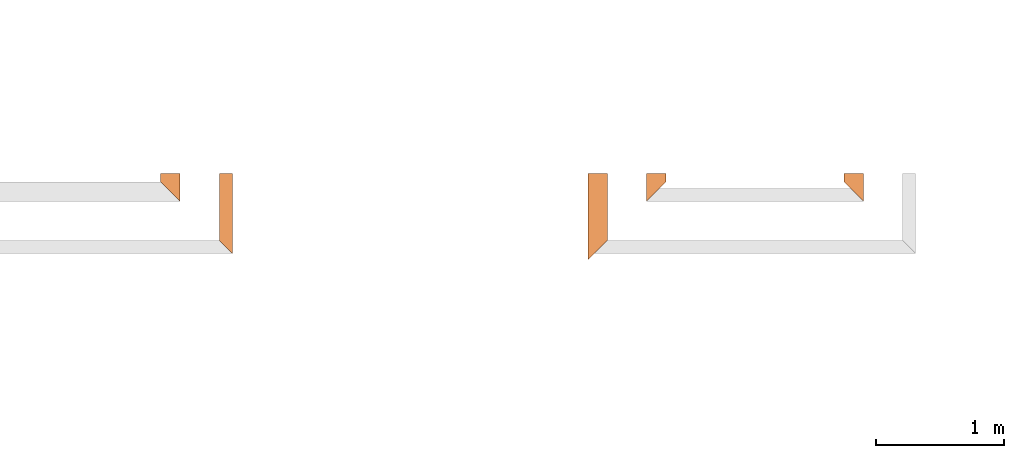
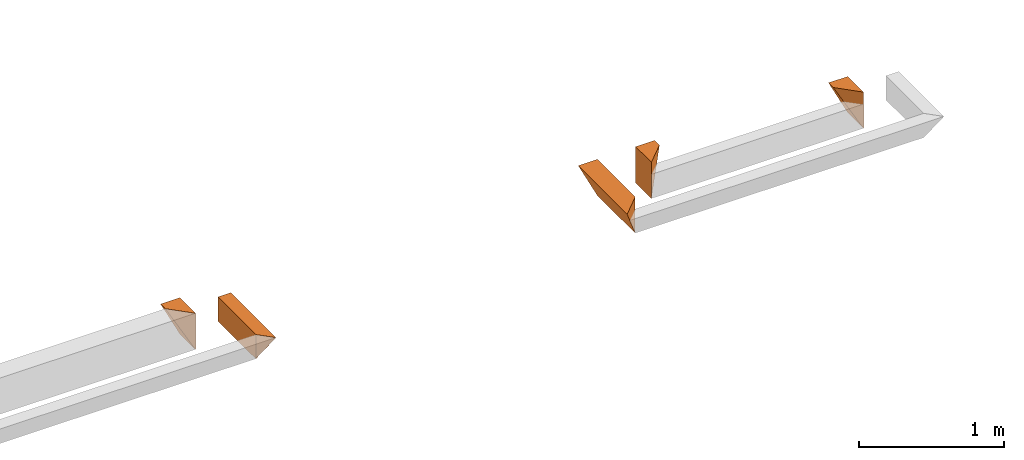
# One storey, part 7 of 8: 5 proxies.
"""IFC4 building model written with IfcOpenShell, lengths in feet."""

import ifcopenshell
import ifcopenshell.guid

model = None  # the IFC model being written
_history = None  # IfcOwnerHistory: only IFC2X3 demands one
_inside = {}  # id of a spatial element -> (the spatial element, [elements in it])
_under = {}  # id of a project, library or spatial element -> (it, [spatial elements below it])
_declared = {}  # id of a project -> (the project, [libraries it declares])
_typed = {}  # id of a type object -> (the type object, [elements of that type])
_made_of = {}  # id of a material, layer set ... -> (it, [elements and type objects made of it])


def new_model(schema):
    """Start an empty IFC model of exactly this schema.

    Asked for "IFC4X3", IfcOpenShell would pick the latest addendum, in which some entities
    have other attributes; the version numbers below select the first issue.
    IFC2X3 requires an IfcOwnerHistory on every rooted entity: one is made here for all.
    """
    global model, _history
    if schema == "IFC4X3":
        model = ifcopenshell.file(schema_version=(4, 3, 0, 0))
    else:
        model = ifcopenshell.file(schema=schema)
    _inside.clear()
    _under.clear()
    _declared.clear()
    _typed.clear()
    _made_of.clear()
    _history = None
    if model.schema == "IFC2X3":
        org = make("IfcOrganization", Name="unknown")
        user = make(
            "IfcPersonAndOrganization",
            ThePerson=make("IfcPerson", FamilyName="unknown"),
            TheOrganization=org,
        )
        app = make(
            "IfcApplication",
            ApplicationDeveloper=org,
            Version="unknown",
            ApplicationFullName="unknown",
            ApplicationIdentifier="unknown",
        )
        _history = make(
            "IfcOwnerHistory",
            OwningUser=user,
            OwningApplication=app,
            ChangeAction="ADDED",
            CreationDate=0,
        )
    return model


def make(cls, **values):
    """One entity of the class cls with the attributes given. An attribute that is None is left unset."""
    return model.create_entity(
        cls, **{name: value for name, value in values.items() if value is not None}
    )


def entity(cls, *values):
    """Any entity or typed value of the class cls, its attributes in the order of the schema. None: left unset."""
    e = model.create_entity(cls)
    for i, value in enumerate(values):
        if value is not None:
            e[i] = value
    return e


def rooted(cls, **values):
    """An entity with a GlobalId (a new one), such as an element, a storey or a relation."""
    return make(cls, GlobalId=ifcopenshell.guid.new(), OwnerHistory=_history, **values)


def si_unit(unit_type, name, prefix=None):
    """IfcSIUnit, for example si_unit("LENGTHUNIT", "METRE", prefix="MILLI")."""
    return make("IfcSIUnit", UnitType=unit_type, Prefix=prefix, Name=name)


def converted_unit(unit_type, name, factor, base, dimensions=None, offset=None):
    """IfcConversionBasedUnit, such as the inch: factor (a typed value) times the base unit."""
    return make(
        "IfcConversionBasedUnit"
        if offset is None
        else "IfcConversionBasedUnitWithOffset",
        ConversionOffset=offset,
        Dimensions=None
        if dimensions is None
        else entity("IfcDimensionalExponents", *dimensions),
        UnitType=unit_type,
        Name=name,
        ConversionFactor=make(
            "IfcMeasureWithUnit", ValueComponent=factor, UnitComponent=base
        ),
    )


def derived_unit(unit_type, elements):
    """IfcDerivedUnit: a product of units, each with its exponent."""
    return make(
        "IfcDerivedUnit",
        Elements=[
            make("IfcDerivedUnitElement", Unit=unit, Exponent=power)
            for unit, power in elements
        ],
        UnitType=unit_type,
    )


def assignment(units):
    """IfcUnitAssignment: the units of a project."""
    return None if units is None else make("IfcUnitAssignment", Units=units)


def point(xyz):
    """IfcCartesianPoint."""
    return None if xyz is None else make("IfcCartesianPoint", Coordinates=xyz)


def direction(xyz):
    """IfcDirection."""
    return None if xyz is None else make("IfcDirection", DirectionRatios=xyz)


def frame(location, z_axis=None, x_axis=None):
    """IfcAxis2Placement3D, a coordinate frame: its origin and axes. An axis left out is left unset."""
    return make(
        "IfcAxis2Placement3D",
        Location=point(location),
        Axis=direction(z_axis),
        RefDirection=direction(x_axis),
    )


def origin():
    """The frame at (0, 0, 0) with its axes left unset."""
    return frame((0.0, 0.0, 0.0))


def place(relative_to, where):
    """IfcLocalPlacement: puts the frame where relative to a parent placement (None: the world)."""
    return make(
        "IfcLocalPlacement", PlacementRelTo=relative_to, RelativePlacement=where
    )


def context(
    kind, dimensions, precision=None, world=None, true_north=None, identifier=None
):
    """IfcGeometricRepresentationContext, for example the 3D "Model" context."""
    return make(
        "IfcGeometricRepresentationContext",
        ContextIdentifier=identifier,
        ContextType=kind,
        CoordinateSpaceDimension=dimensions,
        Precision=precision,
        WorldCoordinateSystem=world,
        TrueNorth=true_north,
    )


def subcontext(parent, identifier, kind, view, scale=None):
    """IfcGeometricRepresentationSubContext, for example "Body" below "Model"."""
    return make(
        "IfcGeometricRepresentationSubContext",
        ContextIdentifier=identifier,
        ContextType=kind,
        ParentContext=parent,
        TargetScale=scale,
        TargetView=view,
    )


def project(units=None, contexts=None):
    """IfcProject with its units and contexts."""
    return rooted(
        "IfcProject",
        Name="project",
        RepresentationContexts=contexts,
        UnitsInContext=assignment(units),
    )


def spatial(cls, under=None, at=None, **own):
    """A site, building, storey or space (cls), placed at a placement, below another one or the project."""
    s = rooted(cls, ObjectPlacement=at, **own)
    if under is not None:
        _under.setdefault(under.id(), (under, []))[1].append(s)
    return s


def shape(context_of_items, identifier, shape_type, items):
    """IfcShapeRepresentation: the items that make up one representation, for example the "Body"."""
    return make(
        "IfcShapeRepresentation",
        ContextOfItems=context_of_items,
        RepresentationIdentifier=identifier,
        RepresentationType=shape_type,
        Items=items,
    )


def made_of(thing, what):
    """Note that an element or type object is made of a material, layer set ...; save() writes the relation."""
    if what is not None:
        _made_of.setdefault(what.id(), (what, []))[1].append(thing)
    return thing


def type_object(cls, material=None, **own):
    """A type object (cls), such as IfcWallType, which elements share."""
    return made_of(rooted(cls, **own), material)


def element(
    cls,
    number,
    at=None,
    inside=None,
    cuts=None,
    type_object=None,
    material=None,
    context=None,
    identifier="Body",
    shape_type=None,
    held_by="IfcProductDefinitionShape",
    body=None,
    shapes=None,
    **own,
):
    """One element of the class cls, such as IfcWall. Its Tag is "e" and its number.

    at: its placement. inside: the storey or other place that contains it. cuts: it is an
    opening in that element (IfcRelVoidsElement). A single representation is given by context,
    identifier, shape_type and body (its items); several are given by shapes. held_by: the class
    of the entity that holds the representations. save() writes the other relations.
    """
    e = rooted(cls, Tag="e%d" % number, ObjectPlacement=at, **own)
    if body is not None:
        shapes = [shape(context, identifier, shape_type, body)]
    if shapes is not None:
        e.Representation = make(held_by, Representations=shapes)
    if inside is not None:
        _inside.setdefault(inside.id(), (inside, []))[1].append(e)
    if cuts is not None:
        rooted(
            "IfcRelVoidsElement", RelatingBuildingElement=cuts, RelatedOpeningElement=e
        )
    if type_object is not None:
        _typed.setdefault(type_object.id(), (type_object, []))[1].append(e)
    return made_of(e, material)


def aggregate(whole, parts):
    """IfcRelAggregates: a whole, such as a stair, and the parts it consists of."""
    return rooted("IfcRelAggregates", RelatingObject=whole, RelatedObjects=parts)


def save(model, path):
    """Write the relations noted so far, then the file.

    IfcRelAggregates (storeys below a building ...), IfcRelContainedInSpatialStructure (elements
    in a storey), IfcRelDefinesByType, IfcRelAssociatesMaterial and IfcRelDeclares: one each for
    every whole, place, type object, material and project.
    """
    for whole, parts in _under.values():
        aggregate(whole, parts)
    for where, things in _inside.values():
        rooted(
            "IfcRelContainedInSpatialStructure",
            RelatedElements=things,
            RelatingStructure=where,
        )
    for kind, things in _typed.values():
        rooted("IfcRelDefinesByType", RelatedObjects=things, RelatingType=kind)
    for what, things in _made_of.values():
        rooted("IfcRelAssociatesMaterial", RelatedObjects=things, RelatingMaterial=what)
    for by, libraries in _declared.values():
        rooted("IfcRelDeclares", RelatingContext=by, RelatedDefinitions=libraries)
    model.write(path)


model = new_model("IFC4")

# Units and contexts
model_context = context("Model", 3, precision=0.0001, world=origin(), true_north=direction((6.12303176911189e-17, 1.0)))
body_context = subcontext(model_context, "Body", "Model", "MODEL_VIEW")
ifc_project = project(units=[converted_unit("LENGTHUNIT", "FOOT", entity("IfcRatioMeasure", 0.3048), si_unit("LENGTHUNIT", "METRE"), dimensions=[1, 0, 0, 0, 0, 0, 0]), converted_unit("AREAUNIT", "SQUARE FOOT", entity("IfcRatioMeasure", 0.09290304), si_unit("AREAUNIT", "SQUARE_METRE"), dimensions=[2, 0, 0, 0, 0, 0, 0]), converted_unit("VOLUMEUNIT", "CUBIC FOOT", entity("IfcRatioMeasure", 0.028316846592), si_unit("VOLUMEUNIT", "CUBIC_METRE"), dimensions=[3, 0, 0, 0, 0, 0, 0]), converted_unit("PLANEANGLEUNIT", "DEGREE", entity("IfcRatioMeasure", 0.0174532925199433), si_unit("PLANEANGLEUNIT", "RADIAN"), dimensions=[0, 0, 0, 0, 0, 0, 0]), si_unit("MASSUNIT", "GRAM", prefix="KILO"), derived_unit("MASSDENSITYUNIT", [(si_unit("MASSUNIT", "GRAM", prefix="KILO"), 1), (si_unit("LENGTHUNIT", "METRE"), -3)]), derived_unit("MOMENTOFINERTIAUNIT", [(si_unit("LENGTHUNIT", "METRE"), 4)]), si_unit("TIMEUNIT", "SECOND"), si_unit("FREQUENCYUNIT", "HERTZ"), si_unit("THERMODYNAMICTEMPERATUREUNIT", "DEGREE_CELSIUS"), derived_unit("THERMALTRANSMITTANCEUNIT", [(si_unit("MASSUNIT", "GRAM", prefix="KILO"), 1), (si_unit("THERMODYNAMICTEMPERATUREUNIT", "KELVIN"), -1), (si_unit("TIMEUNIT", "SECOND"), -3)]), derived_unit("VOLUMETRICFLOWRATEUNIT", [(si_unit("LENGTHUNIT", "METRE"), 3), (si_unit("TIMEUNIT", "SECOND"), -1)]), si_unit("ELECTRICCURRENTUNIT", "AMPERE"), si_unit("ELECTRICVOLTAGEUNIT", "VOLT"), si_unit("POWERUNIT", "WATT"), si_unit("FORCEUNIT", "NEWTON"), si_unit("ILLUMINANCEUNIT", "LUX"), si_unit("LUMINOUSFLUXUNIT", "LUMEN"), si_unit("LUMINOUSINTENSITYUNIT", "CANDELA"), derived_unit("USERDEFINED", [(si_unit("MASSUNIT", "GRAM", prefix="KILO"), -1), (si_unit("LENGTHUNIT", "METRE"), -2), (si_unit("TIMEUNIT", "SECOND"), 3), (si_unit("LUMINOUSFLUXUNIT", "LUMEN"), 1)]), derived_unit("LINEARVELOCITYUNIT", [(si_unit("LENGTHUNIT", "METRE"), 1), (si_unit("TIMEUNIT", "SECOND"), -1)]), si_unit("PRESSUREUNIT", "PASCAL"), derived_unit("USERDEFINED", [(si_unit("LENGTHUNIT", "METRE"), -2), (si_unit("MASSUNIT", "GRAM", prefix="KILO"), 1), (si_unit("TIMEUNIT", "SECOND"), -2)]), derived_unit("LINEARFORCEUNIT", [(si_unit("MASSUNIT", "GRAM", prefix="KILO"), 1), (si_unit("LENGTHUNIT", "METRE"), 1), (si_unit("TIMEUNIT", "SECOND"), -2), (si_unit("LENGTHUNIT", "METRE"), -1)]), derived_unit("PLANARFORCEUNIT", [(si_unit("MASSUNIT", "GRAM", prefix="KILO"), 1), (si_unit("LENGTHUNIT", "METRE"), 1), (si_unit("TIMEUNIT", "SECOND"), -2), (si_unit("LENGTHUNIT", "METRE"), -2)])], contexts=[model_context])

# Site, building, storey
site_placement = place(None, origin())
site = spatial("IfcSite", under=ifc_project, at=site_placement, CompositionType="ELEMENT")
building_placement = place(site_placement, origin())
building = spatial("IfcBuilding", under=site, at=building_placement, CompositionType="ELEMENT")
storey_placement = place(building_placement, frame((0.0, 0.0, -12.6666666666667)))
storey = spatial("IfcBuildingStorey", under=building, at=storey_placement, Name="BASEMENT", CompositionType="ELEMENT", Elevation=-12.6666666666667)

# Proxies
building_element_proxy_type_1 = type_object("IfcBuildingElementProxyType", PredefinedType="NOTDEFINED")
proxy_1_placement = place(storey_placement, frame((-190.196493498266, 957.231726549315, 11.5833333333333)))
cartesian_point_1 = entity("IfcCartesianPoint", [0.5, 0.713552004823441, 0.0])
vertex_point_1 = entity("IfcVertexPoint", cartesian_point_1)
cartesian_point_2 = entity("IfcCartesianPoint", [0.0, 0.713552004823555, 1.0])
vertex_point_2 = entity("IfcVertexPoint", cartesian_point_2)
edge_curve_1 = entity("IfcEdgeCurve", vertex_point_1, vertex_point_2, entity("IfcTrimmedCurve", entity("IfcLine", cartesian_point_1, entity("IfcVector", entity("IfcDirection", [-0.44721359549996, 0.0, 0.894427190999915]), 1.0)), [cartesian_point_1], [cartesian_point_2], True, "CARTESIAN"), True)
cartesian_point_3 = entity("IfcCartesianPoint", [0.5, 0.713552004823441, 1.0])
vertex_point_3 = entity("IfcVertexPoint", cartesian_point_3)
ifc_direction_1 = entity("IfcDirection", [1.0, 0.0, 0.0])
edge_curve_2 = entity("IfcEdgeCurve", vertex_point_2, vertex_point_3, entity("IfcTrimmedCurve", entity("IfcLine", cartesian_point_2, entity("IfcVector", ifc_direction_1, 1.0)), [cartesian_point_2], [cartesian_point_3], True, "CARTESIAN"), True)
cartesian_point_4 = entity("IfcCartesianPoint", [0.5, 0.713552004823441, 0.669270833333341])
vertex_point_4 = entity("IfcVertexPoint", cartesian_point_4)
ifc_direction_2 = entity("IfcDirection", [0.0, 0.0, -1.0])
edge_curve_3 = entity("IfcEdgeCurve", vertex_point_3, vertex_point_4, entity("IfcTrimmedCurve", entity("IfcLine", cartesian_point_3, entity("IfcVector", ifc_direction_2, 1.0)), [cartesian_point_3], [cartesian_point_4], True, "CARTESIAN"), True)
edge_curve_4 = entity("IfcEdgeCurve", vertex_point_4, vertex_point_1, entity("IfcTrimmedCurve", entity("IfcLine", cartesian_point_4, entity("IfcVector", ifc_direction_2, 1.0)), [cartesian_point_4], [cartesian_point_1], True, "CARTESIAN"), True)
ifc_direction_3 = entity("IfcDirection", [0.0, 1.0, 0.0])
cartesian_point_5 = entity("IfcCartesianPoint", [0.0, 0.5, 1.0])
vertex_point_5 = entity("IfcVertexPoint", cartesian_point_5)
cartesian_point_6 = entity("IfcCartesianPoint", [0.499999999999972, 0.0, 0.0])
vertex_point_6 = entity("IfcVertexPoint", cartesian_point_6)
edge_curve_5 = entity("IfcEdgeCurve", vertex_point_5, vertex_point_6, entity("IfcTrimmedCurve", entity("IfcLine", cartesian_point_5, entity("IfcVector", entity("IfcDirection", [0.408248290463845, -0.408248290463868, -0.816496580927733]), 1.0)), [cartesian_point_5], [cartesian_point_6], True, "CARTESIAN"), True)
cartesian_point_7 = entity("IfcCartesianPoint", [0.499999999999972, 0.0, 0.669270833333341])
vertex_point_7 = entity("IfcVertexPoint", cartesian_point_7)
ifc_direction_4 = entity("IfcDirection", [0.0, 0.0, 1.0])
edge_curve_6 = entity("IfcEdgeCurve", vertex_point_6, vertex_point_7, entity("IfcTrimmedCurve", entity("IfcLine", cartesian_point_6, entity("IfcVector", ifc_direction_4, 1.0)), [cartesian_point_6], [cartesian_point_7], True, "CARTESIAN"), True)
cartesian_point_8 = entity("IfcCartesianPoint", [0.499999999999972, 0.0, 1.0])
vertex_point_8 = entity("IfcVertexPoint", cartesian_point_8)
edge_curve_7 = entity("IfcEdgeCurve", vertex_point_7, vertex_point_8, entity("IfcTrimmedCurve", entity("IfcLine", cartesian_point_7, entity("IfcVector", ifc_direction_4, 1.0)), [cartesian_point_7], [cartesian_point_8], True, "CARTESIAN"), True)
edge_curve_8 = entity("IfcEdgeCurve", vertex_point_8, vertex_point_5, entity("IfcTrimmedCurve", entity("IfcLine", cartesian_point_8, entity("IfcVector", entity("IfcDirection", [-0.707106781186527, 0.707106781186568, 0.0]), 1.0)), [cartesian_point_8], [cartesian_point_5], True, "CARTESIAN"), True)
ifc_direction_5 = entity("IfcDirection", [0.0, -1.0, 0.0])
edge_curve_9 = entity("IfcEdgeCurve", vertex_point_1, vertex_point_6, entity("IfcTrimmedCurve", entity("IfcLine", cartesian_point_1, entity("IfcVector", ifc_direction_5, 1.0)), [cartesian_point_1], [cartesian_point_6], True, "CARTESIAN"), True)
edge_curve_10 = entity("IfcEdgeCurve", vertex_point_5, vertex_point_2, entity("IfcTrimmedCurve", entity("IfcLine", cartesian_point_2, entity("IfcVector", ifc_direction_3, 1.0)), [cartesian_point_5], [cartesian_point_2], True, "CARTESIAN"), True)
edge_curve_11 = entity("IfcEdgeCurve", vertex_point_8, vertex_point_3, entity("IfcTrimmedCurve", entity("IfcLine", cartesian_point_3, entity("IfcVector", ifc_direction_3, 1.0)), [cartesian_point_8], [cartesian_point_3], True, "CARTESIAN"), True)
element("IfcBuildingElementProxy", 1, at=proxy_1_placement, inside=storey, type_object=building_element_proxy_type_1, PredefinedType="NOTDEFINED", context=body_context, shape_type="AdvancedBrep", body=[
    entity("IfcAdvancedBrep", entity("IfcClosedShell", [entity("IfcAdvancedFace", [entity("IfcFaceOuterBound", entity("IfcEdgeLoop", [entity("IfcOrientedEdge", None, None, edge_curve_1, True), entity("IfcOrientedEdge", None, None, edge_curve_2, True), entity("IfcOrientedEdge", None, None, edge_curve_3, True), entity("IfcOrientedEdge", None, None, edge_curve_4, True)]), True)], entity("IfcPlane", entity("IfcAxis2Placement3D", entity("IfcCartesianPoint", [-0.5, 0.713552004823555, 1.0]), ifc_direction_3, ifc_direction_2)), True), entity("IfcAdvancedFace", [entity("IfcFaceOuterBound", entity("IfcEdgeLoop", [entity("IfcOrientedEdge", None, None, edge_curve_5, True), entity("IfcOrientedEdge", None, None, edge_curve_6, True), entity("IfcOrientedEdge", None, None, edge_curve_7, True), entity("IfcOrientedEdge", None, None, edge_curve_8, True)]), True)], entity("IfcPlane", entity("IfcAxis2Placement3D", entity("IfcCartesianPoint", [0.499999999999972, 0.0, 2.0]), entity("IfcDirection", [-0.707106781186562, -0.707106781186533, 0.0]), entity("IfcDirection", [-0.707106781186533, 0.707106781186562, 0.0]))), True), entity("IfcAdvancedFace", [entity("IfcFaceOuterBound", entity("IfcEdgeLoop", [entity("IfcOrientedEdge", None, None, edge_curve_1, False), entity("IfcOrientedEdge", None, None, edge_curve_9, True), entity("IfcOrientedEdge", None, None, edge_curve_5, False), entity("IfcOrientedEdge", None, None, edge_curve_10, True)]), True)], entity("IfcPlane", entity("IfcAxis2Placement3D", cartesian_point_1, entity("IfcDirection", [-0.894427190999915, 0.0, -0.447213595499961]), ifc_direction_5)), True), entity("IfcAdvancedFace", [entity("IfcFaceOuterBound", entity("IfcEdgeLoop", [entity("IfcOrientedEdge", None, None, edge_curve_2, False), entity("IfcOrientedEdge", None, None, edge_curve_10, False), entity("IfcOrientedEdge", None, None, edge_curve_8, False), entity("IfcOrientedEdge", None, None, edge_curve_11, True)]), True)], entity("IfcPlane", entity("IfcAxis2Placement3D", cartesian_point_2, ifc_direction_4, ifc_direction_5)), True), entity("IfcAdvancedFace", [entity("IfcFaceOuterBound", entity("IfcEdgeLoop", [entity("IfcOrientedEdge", None, None, edge_curve_11, False), entity("IfcOrientedEdge", None, None, edge_curve_7, False), entity("IfcOrientedEdge", None, None, edge_curve_6, False), entity("IfcOrientedEdge", None, None, edge_curve_9, False), entity("IfcOrientedEdge", None, None, edge_curve_4, False), entity("IfcOrientedEdge", None, None, edge_curve_3, False)]), True)], entity("IfcPlane", entity("IfcAxis2Placement3D", cartesian_point_3, ifc_direction_1, ifc_direction_5)), True)])),
])
building_element_proxy_type_2 = type_object("IfcBuildingElementProxyType", PredefinedType="NOTDEFINED")
proxy_2_placement = place(storey_placement, frame((-188.696493498266, 955.897091132648, 11.5833333333333)))
cartesian_point_9 = entity("IfcCartesianPoint", [0.0, 2.04818742149018, 0.0])
vertex_point_9 = entity("IfcVertexPoint", cartesian_point_9)
cartesian_point_10 = entity("IfcCartesianPoint", [0.0, 2.04818742149018, 0.669270833333343])
vertex_point_10 = entity("IfcVertexPoint", cartesian_point_10)
ifc_direction_6 = entity("IfcDirection", [0.0, 0.0, 1.0])
edge_curve_12 = entity("IfcEdgeCurve", vertex_point_9, vertex_point_10, entity("IfcTrimmedCurve", entity("IfcLine", cartesian_point_9, entity("IfcVector", ifc_direction_6, 1.0)), [cartesian_point_9], [cartesian_point_10], True, "CARTESIAN"), True)
cartesian_point_11 = entity("IfcCartesianPoint", [0.334635416666828, 2.04818742149018, 0.669270833333343])
vertex_point_11 = entity("IfcVertexPoint", cartesian_point_11)
ifc_direction_7 = entity("IfcDirection", [1.0, 0.0, 0.0])
edge_curve_13 = entity("IfcEdgeCurve", vertex_point_10, vertex_point_11, entity("IfcTrimmedCurve", entity("IfcLine", cartesian_point_10, entity("IfcVector", ifc_direction_7, 1.0)), [cartesian_point_10], [cartesian_point_11], True, "CARTESIAN"), True)
edge_curve_14 = entity("IfcEdgeCurve", vertex_point_11, vertex_point_9, entity("IfcTrimmedCurve", entity("IfcLine", cartesian_point_11, entity("IfcVector", entity("IfcDirection", [-0.447213595499947, 0.0, -0.894427190999921]), 1.0)), [cartesian_point_11], [cartesian_point_9], True, "CARTESIAN"), True)
ifc_direction_8 = entity("IfcDirection", [0.0, 1.0, 0.0])
ifc_direction_9 = entity("IfcDirection", [0.0, 0.0, -1.0])
cartesian_point_12 = entity("IfcCartesianPoint", [0.0, 0.334635416666742, 0.0])
vertex_point_12 = entity("IfcVertexPoint", cartesian_point_12)
cartesian_point_13 = entity("IfcCartesianPoint", [0.334635416666771, 0.0, 0.669270833333343])
vertex_point_13 = entity("IfcVertexPoint", cartesian_point_13)
edge_curve_15 = entity("IfcEdgeCurve", vertex_point_12, vertex_point_13, entity("IfcTrimmedCurve", entity("IfcLine", cartesian_point_12, entity("IfcVector", entity("IfcDirection", [0.40824829046386, -0.408248290463825, 0.816496580927747]), 1.0)), [cartesian_point_12], [cartesian_point_13], True, "CARTESIAN"), True)
cartesian_point_14 = entity("IfcCartesianPoint", [0.0, 0.334635416666856, 0.669270833333343])
vertex_point_14 = entity("IfcVertexPoint", cartesian_point_14)
edge_curve_16 = entity("IfcEdgeCurve", vertex_point_13, vertex_point_14, entity("IfcTrimmedCurve", entity("IfcLine", cartesian_point_13, entity("IfcVector", entity("IfcDirection", [-0.707106781186488, 0.707106781186608, 0.0]), 1.0)), [cartesian_point_13], [cartesian_point_14], True, "CARTESIAN"), True)
edge_curve_17 = entity("IfcEdgeCurve", vertex_point_14, vertex_point_12, entity("IfcTrimmedCurve", entity("IfcLine", cartesian_point_14, entity("IfcVector", ifc_direction_9, 1.0)), [cartesian_point_14], [cartesian_point_12], True, "CARTESIAN"), True)
ifc_direction_10 = entity("IfcDirection", [0.0, -1.0, 0.0])
edge_curve_18 = entity("IfcEdgeCurve", vertex_point_9, vertex_point_12, entity("IfcTrimmedCurve", entity("IfcLine", cartesian_point_9, entity("IfcVector", ifc_direction_10, 1.0)), [cartesian_point_9], [cartesian_point_12], True, "CARTESIAN"), True)
edge_curve_19 = entity("IfcEdgeCurve", vertex_point_14, vertex_point_10, entity("IfcTrimmedCurve", entity("IfcLine", cartesian_point_14, entity("IfcVector", ifc_direction_8, 1.0)), [cartesian_point_14], [cartesian_point_10], True, "CARTESIAN"), True)
edge_curve_20 = entity("IfcEdgeCurve", vertex_point_11, vertex_point_13, entity("IfcTrimmedCurve", entity("IfcLine", cartesian_point_11, entity("IfcVector", ifc_direction_10, 1.0)), [cartesian_point_11], [cartesian_point_13], True, "CARTESIAN"), True)
element("IfcBuildingElementProxy", 2, at=proxy_2_placement, inside=storey, type_object=building_element_proxy_type_2, PredefinedType="NOTDEFINED", context=body_context, shape_type="AdvancedBrep", body=[
    entity("IfcAdvancedBrep", entity("IfcClosedShell", [entity("IfcAdvancedFace", [entity("IfcFaceOuterBound", entity("IfcEdgeLoop", [entity("IfcOrientedEdge", None, None, edge_curve_12, True), entity("IfcOrientedEdge", None, None, edge_curve_13, True), entity("IfcOrientedEdge", None, None, edge_curve_14, True)]), True)], entity("IfcPlane", entity("IfcAxis2Placement3D", entity("IfcCartesianPoint", [-1.0, 2.0481874214903, 1.0]), ifc_direction_8, ifc_direction_9)), True), entity("IfcAdvancedFace", [entity("IfcFaceOuterBound", entity("IfcEdgeLoop", [entity("IfcOrientedEdge", None, None, edge_curve_15, True), entity("IfcOrientedEdge", None, None, edge_curve_16, True), entity("IfcOrientedEdge", None, None, edge_curve_17, True)]), True)], entity("IfcPlane", entity("IfcAxis2Placement3D", entity("IfcCartesianPoint", [0.0, 0.334635416666742, 2.0]), entity("IfcDirection", [-0.707106781186562, -0.707106781186533, 0.0]), entity("IfcDirection", [-0.707106781186533, 0.707106781186562, 0.0]))), True), entity("IfcAdvancedFace", [entity("IfcFaceOuterBound", entity("IfcEdgeLoop", [entity("IfcOrientedEdge", None, None, edge_curve_18, True), entity("IfcOrientedEdge", None, None, edge_curve_17, False), entity("IfcOrientedEdge", None, None, edge_curve_19, True), entity("IfcOrientedEdge", None, None, edge_curve_12, False)]), True)], entity("IfcPlane", entity("IfcAxis2Placement3D", cartesian_point_9, entity("IfcDirection", [-1.0, 0.0, 0.0]), ifc_direction_10)), True), entity("IfcAdvancedFace", [entity("IfcFaceOuterBound", entity("IfcEdgeLoop", [entity("IfcOrientedEdge", None, None, edge_curve_18, False), entity("IfcOrientedEdge", None, None, edge_curve_14, False), entity("IfcOrientedEdge", None, None, edge_curve_20, True), entity("IfcOrientedEdge", None, None, edge_curve_15, False)]), True)], entity("IfcPlane", entity("IfcAxis2Placement3D", entity("IfcCartesianPoint", [0.500000000000171, 2.04818742149018, 1.0]), entity("IfcDirection", [0.894427190999915, 0.0, -0.447213595499961]), ifc_direction_10)), True), entity("IfcAdvancedFace", [entity("IfcFaceOuterBound", entity("IfcEdgeLoop", [entity("IfcOrientedEdge", None, None, edge_curve_13, False), entity("IfcOrientedEdge", None, None, edge_curve_19, False), entity("IfcOrientedEdge", None, None, edge_curve_16, False), entity("IfcOrientedEdge", None, None, edge_curve_20, False)]), True)], entity("IfcPlane", entity("IfcAxis2Placement3D", entity("IfcCartesianPoint", [46.9583406872922, 2.96484375000227, 0.669270833333343]), ifc_direction_6, ifc_direction_7)), True)])),
])
building_element_proxy_type_3 = type_object("IfcBuildingElementProxyType", PredefinedType="NOTDEFINED")
proxy_3_placement = place(storey_placement, frame((-172.738160287975, 957.231726549315, 11.5833333333333)))
cartesian_point_15 = entity("IfcCartesianPoint", [0.5, 0.713552004823214, 0.0])
vertex_point_15 = entity("IfcVertexPoint", cartesian_point_15)
cartesian_point_16 = entity("IfcCartesianPoint", [0.0, 0.713552004823214, 1.0])
vertex_point_16 = entity("IfcVertexPoint", cartesian_point_16)
edge_curve_21 = entity("IfcEdgeCurve", vertex_point_15, vertex_point_16, entity("IfcTrimmedCurve", entity("IfcLine", cartesian_point_15, entity("IfcVector", entity("IfcDirection", [-0.44721359549996, 0.0, 0.894427190999915]), 1.0)), [cartesian_point_15], [cartesian_point_16], True, "CARTESIAN"), True)
cartesian_point_17 = entity("IfcCartesianPoint", [0.5, 0.713552004823214, 1.0])
vertex_point_17 = entity("IfcVertexPoint", cartesian_point_17)
ifc_direction_11 = entity("IfcDirection", [1.0, 0.0, 0.0])
edge_curve_22 = entity("IfcEdgeCurve", vertex_point_16, vertex_point_17, entity("IfcTrimmedCurve", entity("IfcLine", cartesian_point_16, entity("IfcVector", ifc_direction_11, 1.0)), [cartesian_point_16], [cartesian_point_17], True, "CARTESIAN"), True)
cartesian_point_18 = entity("IfcCartesianPoint", [0.5, 0.713552004823214, 0.669270833333341])
vertex_point_18 = entity("IfcVertexPoint", cartesian_point_18)
ifc_direction_12 = entity("IfcDirection", [0.0, 0.0, -1.0])
edge_curve_23 = entity("IfcEdgeCurve", vertex_point_17, vertex_point_18, entity("IfcTrimmedCurve", entity("IfcLine", cartesian_point_17, entity("IfcVector", ifc_direction_12, 1.0)), [cartesian_point_17], [cartesian_point_18], True, "CARTESIAN"), True)
edge_curve_24 = entity("IfcEdgeCurve", vertex_point_18, vertex_point_15, entity("IfcTrimmedCurve", entity("IfcLine", cartesian_point_18, entity("IfcVector", ifc_direction_12, 1.0)), [cartesian_point_18], [cartesian_point_15], True, "CARTESIAN"), True)
ifc_direction_13 = entity("IfcDirection", [0.0, 1.0, 0.0])
cartesian_point_19 = entity("IfcCartesianPoint", [0.0, 0.500000000000114, 1.0])
vertex_point_19 = entity("IfcVertexPoint", cartesian_point_19)
cartesian_point_20 = entity("IfcCartesianPoint", [0.499999999999972, 0.0, 0.0])
vertex_point_20 = entity("IfcVertexPoint", cartesian_point_20)
edge_curve_25 = entity("IfcEdgeCurve", vertex_point_19, vertex_point_20, entity("IfcTrimmedCurve", entity("IfcLine", cartesian_point_19, entity("IfcVector", entity("IfcDirection", [0.408248290463845, -0.408248290463868, -0.816496580927733]), 1.0)), [cartesian_point_19], [cartesian_point_20], True, "CARTESIAN"), True)
cartesian_point_21 = entity("IfcCartesianPoint", [0.499999999999972, 0.0, 0.669270833333341])
vertex_point_21 = entity("IfcVertexPoint", cartesian_point_21)
ifc_direction_14 = entity("IfcDirection", [0.0, 0.0, 1.0])
edge_curve_26 = entity("IfcEdgeCurve", vertex_point_20, vertex_point_21, entity("IfcTrimmedCurve", entity("IfcLine", cartesian_point_20, entity("IfcVector", ifc_direction_14, 1.0)), [cartesian_point_20], [cartesian_point_21], True, "CARTESIAN"), True)
cartesian_point_22 = entity("IfcCartesianPoint", [0.499999999999972, 0.0, 1.0])
vertex_point_22 = entity("IfcVertexPoint", cartesian_point_22)
edge_curve_27 = entity("IfcEdgeCurve", vertex_point_21, vertex_point_22, entity("IfcTrimmedCurve", entity("IfcLine", cartesian_point_21, entity("IfcVector", ifc_direction_14, 1.0)), [cartesian_point_21], [cartesian_point_22], True, "CARTESIAN"), True)
edge_curve_28 = entity("IfcEdgeCurve", vertex_point_22, vertex_point_19, entity("IfcTrimmedCurve", entity("IfcLine", cartesian_point_22, entity("IfcVector", entity("IfcDirection", [-0.707106781186527, 0.707106781186568, 0.0]), 1.0)), [cartesian_point_22], [cartesian_point_19], True, "CARTESIAN"), True)
ifc_direction_15 = entity("IfcDirection", [0.0, -1.0, 0.0])
edge_curve_29 = entity("IfcEdgeCurve", vertex_point_15, vertex_point_20, entity("IfcTrimmedCurve", entity("IfcLine", cartesian_point_15, entity("IfcVector", ifc_direction_15, 1.0)), [cartesian_point_15], [cartesian_point_20], True, "CARTESIAN"), True)
edge_curve_30 = entity("IfcEdgeCurve", vertex_point_19, vertex_point_16, entity("IfcTrimmedCurve", entity("IfcLine", cartesian_point_16, entity("IfcVector", ifc_direction_13, 1.0)), [cartesian_point_19], [cartesian_point_16], True, "CARTESIAN"), True)
edge_curve_31 = entity("IfcEdgeCurve", vertex_point_22, vertex_point_17, entity("IfcTrimmedCurve", entity("IfcLine", cartesian_point_17, entity("IfcVector", ifc_direction_13, 1.0)), [cartesian_point_22], [cartesian_point_17], True, "CARTESIAN"), True)
element("IfcBuildingElementProxy", 3, at=proxy_3_placement, inside=storey, type_object=building_element_proxy_type_3, PredefinedType="NOTDEFINED", context=body_context, shape_type="AdvancedBrep", body=[
    entity("IfcAdvancedBrep", entity("IfcClosedShell", [entity("IfcAdvancedFace", [entity("IfcFaceOuterBound", entity("IfcEdgeLoop", [entity("IfcOrientedEdge", None, None, edge_curve_21, True), entity("IfcOrientedEdge", None, None, edge_curve_22, True), entity("IfcOrientedEdge", None, None, edge_curve_23, True), entity("IfcOrientedEdge", None, None, edge_curve_24, True)]), True)], entity("IfcPlane", entity("IfcAxis2Placement3D", entity("IfcCartesianPoint", [-0.5, 0.713552004823214, 1.0]), ifc_direction_13, ifc_direction_12)), True), entity("IfcAdvancedFace", [entity("IfcFaceOuterBound", entity("IfcEdgeLoop", [entity("IfcOrientedEdge", None, None, edge_curve_25, True), entity("IfcOrientedEdge", None, None, edge_curve_26, True), entity("IfcOrientedEdge", None, None, edge_curve_27, True), entity("IfcOrientedEdge", None, None, edge_curve_28, True)]), True)], entity("IfcPlane", entity("IfcAxis2Placement3D", entity("IfcCartesianPoint", [0.499999999999972, 0.0, 2.0]), entity("IfcDirection", [-0.707106781186562, -0.707106781186533, 0.0]), entity("IfcDirection", [-0.707106781186533, 0.707106781186562, 0.0]))), True), entity("IfcAdvancedFace", [entity("IfcFaceOuterBound", entity("IfcEdgeLoop", [entity("IfcOrientedEdge", None, None, edge_curve_21, False), entity("IfcOrientedEdge", None, None, edge_curve_29, True), entity("IfcOrientedEdge", None, None, edge_curve_25, False), entity("IfcOrientedEdge", None, None, edge_curve_30, True)]), True)], entity("IfcPlane", entity("IfcAxis2Placement3D", cartesian_point_15, entity("IfcDirection", [-0.894427190999915, 0.0, -0.447213595499961]), ifc_direction_15)), True), entity("IfcAdvancedFace", [entity("IfcFaceOuterBound", entity("IfcEdgeLoop", [entity("IfcOrientedEdge", None, None, edge_curve_22, False), entity("IfcOrientedEdge", None, None, edge_curve_30, False), entity("IfcOrientedEdge", None, None, edge_curve_28, False), entity("IfcOrientedEdge", None, None, edge_curve_31, True)]), True)], entity("IfcPlane", entity("IfcAxis2Placement3D", cartesian_point_16, ifc_direction_14, ifc_direction_15)), True), entity("IfcAdvancedFace", [entity("IfcFaceOuterBound", entity("IfcEdgeLoop", [entity("IfcOrientedEdge", None, None, edge_curve_31, False), entity("IfcOrientedEdge", None, None, edge_curve_27, False), entity("IfcOrientedEdge", None, None, edge_curve_26, False), entity("IfcOrientedEdge", None, None, edge_curve_29, False), entity("IfcOrientedEdge", None, None, edge_curve_24, False), entity("IfcOrientedEdge", None, None, edge_curve_23, False)]), True)], entity("IfcPlane", entity("IfcAxis2Placement3D", cartesian_point_17, ifc_direction_11, ifc_direction_15)), True)])),
])
building_element_proxy_type_4 = type_object("IfcBuildingElementProxyType", PredefinedType="NOTDEFINED")
proxy_4_placement = place(storey_placement, frame((-177.779827442686, 957.231726549315, 11.5833333333333)))
cartesian_point_23 = entity("IfcCartesianPoint", [0.0, 0.7135520048231, 0.0])
vertex_point_23 = entity("IfcVertexPoint", cartesian_point_23)
cartesian_point_24 = entity("IfcCartesianPoint", [0.0, 0.7135520048231, 1.0])
vertex_point_24 = entity("IfcVertexPoint", cartesian_point_24)
ifc_direction_16 = entity("IfcDirection", [0.0, 0.0, 1.0])
edge_curve_32 = entity("IfcEdgeCurve", vertex_point_23, vertex_point_24, entity("IfcTrimmedCurve", entity("IfcLine", cartesian_point_23, entity("IfcVector", ifc_direction_16, 1.0)), [cartesian_point_23], [cartesian_point_24], True, "CARTESIAN"), True)
cartesian_point_25 = entity("IfcCartesianPoint", [0.5, 0.713552004823214, 1.0])
vertex_point_25 = entity("IfcVertexPoint", cartesian_point_25)
edge_curve_33 = entity("IfcEdgeCurve", vertex_point_24, vertex_point_25, entity("IfcTrimmedCurve", entity("IfcLine", cartesian_point_24, entity("IfcVector", entity("IfcDirection", [1.0, 0.0, 0.0]), 1.0)), [cartesian_point_24], [cartesian_point_25], True, "CARTESIAN"), True)
edge_curve_34 = entity("IfcEdgeCurve", vertex_point_25, vertex_point_23, entity("IfcTrimmedCurve", entity("IfcLine", cartesian_point_25, entity("IfcVector", entity("IfcDirection", [-0.44721359549996, 0.0, -0.894427190999915]), 1.0)), [cartesian_point_25], [cartesian_point_23], True, "CARTESIAN"), True)
ifc_direction_17 = entity("IfcDirection", [0.0, 1.0, 0.0])
ifc_direction_18 = entity("IfcDirection", [0.0, 0.0, -1.0])
cartesian_point_26 = entity("IfcCartesianPoint", [0.0, 0.0, 0.0])
vertex_point_26 = entity("IfcVertexPoint", cartesian_point_26)
cartesian_point_27 = entity("IfcCartesianPoint", [0.500000000000028, 0.5, 1.0])
vertex_point_27 = entity("IfcVertexPoint", cartesian_point_27)
edge_curve_35 = entity("IfcEdgeCurve", vertex_point_26, vertex_point_27, entity("IfcTrimmedCurve", entity("IfcLine", cartesian_point_26, entity("IfcVector", entity("IfcDirection", [0.408248290463864, 0.408248290463864, 0.816496580927725]), 1.0)), [cartesian_point_26], [cartesian_point_27], True, "CARTESIAN"), True)
cartesian_point_28 = entity("IfcCartesianPoint", [0.0, 0.0, 1.0])
vertex_point_28 = entity("IfcVertexPoint", cartesian_point_28)
edge_curve_36 = entity("IfcEdgeCurve", vertex_point_27, vertex_point_28, entity("IfcTrimmedCurve", entity("IfcLine", cartesian_point_27, entity("IfcVector", entity("IfcDirection", [-0.707106781186547, -0.707106781186547, 0.0]), 1.0)), [cartesian_point_27], [cartesian_point_28], True, "CARTESIAN"), True)
edge_curve_37 = entity("IfcEdgeCurve", vertex_point_28, vertex_point_26, entity("IfcTrimmedCurve", entity("IfcLine", cartesian_point_28, entity("IfcVector", ifc_direction_18, 1.0)), [cartesian_point_28], [cartesian_point_26], True, "CARTESIAN"), True)
ifc_direction_19 = entity("IfcDirection", [0.0, -1.0, 0.0])
edge_curve_38 = entity("IfcEdgeCurve", vertex_point_25, vertex_point_27, entity("IfcTrimmedCurve", entity("IfcLine", cartesian_point_25, entity("IfcVector", ifc_direction_19, 1.0)), [cartesian_point_25], [cartesian_point_27], True, "CARTESIAN"), True)
edge_curve_39 = entity("IfcEdgeCurve", vertex_point_26, vertex_point_23, entity("IfcTrimmedCurve", entity("IfcLine", cartesian_point_23, entity("IfcVector", ifc_direction_17, 1.0)), [cartesian_point_26], [cartesian_point_23], True, "CARTESIAN"), True)
edge_curve_40 = entity("IfcEdgeCurve", vertex_point_24, vertex_point_28, entity("IfcTrimmedCurve", entity("IfcLine", cartesian_point_24, entity("IfcVector", ifc_direction_19, 1.0)), [cartesian_point_24], [cartesian_point_28], True, "CARTESIAN"), True)
element("IfcBuildingElementProxy", 4, at=proxy_4_placement, inside=storey, type_object=building_element_proxy_type_4, PredefinedType="NOTDEFINED", context=body_context, shape_type="AdvancedBrep", body=[
    entity("IfcAdvancedBrep", entity("IfcClosedShell", [entity("IfcAdvancedFace", [entity("IfcFaceOuterBound", entity("IfcEdgeLoop", [entity("IfcOrientedEdge", None, None, edge_curve_32, True), entity("IfcOrientedEdge", None, None, edge_curve_33, True), entity("IfcOrientedEdge", None, None, edge_curve_34, True)]), True)], entity("IfcPlane", entity("IfcAxis2Placement3D", entity("IfcCartesianPoint", [-1.0, 0.7135520048231, 1.0]), ifc_direction_17, ifc_direction_18)), True), entity("IfcAdvancedFace", [entity("IfcFaceOuterBound", entity("IfcEdgeLoop", [entity("IfcOrientedEdge", None, None, edge_curve_35, True), entity("IfcOrientedEdge", None, None, edge_curve_36, True), entity("IfcOrientedEdge", None, None, edge_curve_37, True)]), True)], entity("IfcPlane", entity("IfcAxis2Placement3D", cartesian_point_26, entity("IfcDirection", [0.707106781186548, -0.707106781186548, 0.0]), entity("IfcDirection", [0.707106781186548, 0.707106781186548, 0.0]))), True), entity("IfcAdvancedFace", [entity("IfcFaceOuterBound", entity("IfcEdgeLoop", [entity("IfcOrientedEdge", None, None, edge_curve_34, False), entity("IfcOrientedEdge", None, None, edge_curve_38, True), entity("IfcOrientedEdge", None, None, edge_curve_35, False), entity("IfcOrientedEdge", None, None, edge_curve_39, True)]), True)], entity("IfcPlane", entity("IfcAxis2Placement3D", cartesian_point_25, entity("IfcDirection", [0.894427190999915, 0.0, -0.447213595499961]), ifc_direction_19)), True), entity("IfcAdvancedFace", [entity("IfcFaceOuterBound", entity("IfcEdgeLoop", [entity("IfcOrientedEdge", None, None, edge_curve_33, False), entity("IfcOrientedEdge", None, None, edge_curve_40, True), entity("IfcOrientedEdge", None, None, edge_curve_36, False), entity("IfcOrientedEdge", None, None, edge_curve_38, False)]), True)], entity("IfcPlane", entity("IfcAxis2Placement3D", cartesian_point_24, ifc_direction_16, ifc_direction_19)), True), entity("IfcAdvancedFace", [entity("IfcFaceOuterBound", entity("IfcEdgeLoop", [entity("IfcOrientedEdge", None, None, edge_curve_32, False), entity("IfcOrientedEdge", None, None, edge_curve_39, False), entity("IfcOrientedEdge", None, None, edge_curve_37, False), entity("IfcOrientedEdge", None, None, edge_curve_40, False)]), True)], entity("IfcPlane", entity("IfcAxis2Placement3D", cartesian_point_23, entity("IfcDirection", [-1.0, 0.0, 0.0]), ifc_direction_19)), True)])),
])
building_element_proxy_type_5 = type_object("IfcBuildingElementProxyType", PredefinedType="NOTDEFINED")
proxy_5_placement = place(storey_placement, frame((-179.279827442686, 955.731726549315, 11.5833333333333)))
cartesian_point_29 = entity("IfcCartesianPoint", [0.5, 2.21355200482321, 0.0])
vertex_point_29 = entity("IfcVertexPoint", cartesian_point_29)
cartesian_point_30 = entity("IfcCartesianPoint", [0.0, 2.21355200482321, 1.0])
vertex_point_30 = entity("IfcVertexPoint", cartesian_point_30)
edge_curve_41 = entity("IfcEdgeCurve", vertex_point_29, vertex_point_30, entity("IfcTrimmedCurve", entity("IfcLine", cartesian_point_29, entity("IfcVector", entity("IfcDirection", [-0.44721359549996, 0.0, 0.894427190999915]), 1.0)), [cartesian_point_29], [cartesian_point_30], True, "CARTESIAN"), True)
cartesian_point_31 = entity("IfcCartesianPoint", [0.5, 2.21355200482321, 1.0])
vertex_point_31 = entity("IfcVertexPoint", cartesian_point_31)
ifc_direction_20 = entity("IfcDirection", [1.0, 0.0, 0.0])
edge_curve_42 = entity("IfcEdgeCurve", vertex_point_30, vertex_point_31, entity("IfcTrimmedCurve", entity("IfcLine", cartesian_point_30, entity("IfcVector", ifc_direction_20, 1.0)), [cartesian_point_30], [cartesian_point_31], True, "CARTESIAN"), True)
ifc_direction_21 = entity("IfcDirection", [0.0, 0.0, -1.0])
edge_curve_43 = entity("IfcEdgeCurve", vertex_point_31, vertex_point_29, entity("IfcTrimmedCurve", entity("IfcLine", cartesian_point_31, entity("IfcVector", ifc_direction_21, 1.0)), [cartesian_point_31], [cartesian_point_29], True, "CARTESIAN"), True)
ifc_direction_22 = entity("IfcDirection", [0.0, 1.0, 0.0])
cartesian_point_32 = entity("IfcCartesianPoint", [0.500000000000057, 0.500000000000114, 0.0])
vertex_point_32 = entity("IfcVertexPoint", cartesian_point_32)
cartesian_point_33 = entity("IfcCartesianPoint", [0.500000000000057, 0.500000000000114, 1.0])
vertex_point_33 = entity("IfcVertexPoint", cartesian_point_33)
ifc_direction_23 = entity("IfcDirection", [0.0, 0.0, 1.0])
edge_curve_44 = entity("IfcEdgeCurve", vertex_point_32, vertex_point_33, entity("IfcTrimmedCurve", entity("IfcLine", cartesian_point_32, entity("IfcVector", ifc_direction_23, 1.0)), [cartesian_point_32], [cartesian_point_33], True, "CARTESIAN"), True)
cartesian_point_34 = entity("IfcCartesianPoint", [0.0, 0.0, 1.0])
vertex_point_34 = entity("IfcVertexPoint", cartesian_point_34)
edge_curve_45 = entity("IfcEdgeCurve", vertex_point_33, vertex_point_34, entity("IfcTrimmedCurve", entity("IfcLine", cartesian_point_33, entity("IfcVector", entity("IfcDirection", [-0.707106781186547, -0.707106781186547, 0.0]), 1.0)), [cartesian_point_33], [cartesian_point_34], True, "CARTESIAN"), True)
edge_curve_46 = entity("IfcEdgeCurve", vertex_point_34, vertex_point_32, entity("IfcTrimmedCurve", entity("IfcLine", cartesian_point_34, entity("IfcVector", entity("IfcDirection", [0.408248290463865, 0.408248290463865, -0.816496580927724]), 1.0)), [cartesian_point_34], [cartesian_point_32], True, "CARTESIAN"), True)
ifc_direction_24 = entity("IfcDirection", [0.0, -1.0, 0.0])
edge_curve_47 = entity("IfcEdgeCurve", vertex_point_31, vertex_point_33, entity("IfcTrimmedCurve", entity("IfcLine", cartesian_point_31, entity("IfcVector", ifc_direction_24, 1.0)), [cartesian_point_31], [cartesian_point_33], True, "CARTESIAN"), True)
edge_curve_48 = entity("IfcEdgeCurve", vertex_point_32, vertex_point_29, entity("IfcTrimmedCurve", entity("IfcLine", cartesian_point_29, entity("IfcVector", ifc_direction_22, 1.0)), [cartesian_point_32], [cartesian_point_29], True, "CARTESIAN"), True)
edge_curve_49 = entity("IfcEdgeCurve", vertex_point_30, vertex_point_34, entity("IfcTrimmedCurve", entity("IfcLine", cartesian_point_30, entity("IfcVector", ifc_direction_24, 1.0)), [cartesian_point_30], [cartesian_point_34], True, "CARTESIAN"), True)
element("IfcBuildingElementProxy", 5, at=proxy_5_placement, inside=storey, type_object=building_element_proxy_type_5, PredefinedType="NOTDEFINED", context=body_context, shape_type="AdvancedBrep", body=[
    entity("IfcAdvancedBrep", entity("IfcClosedShell", [entity("IfcAdvancedFace", [entity("IfcFaceOuterBound", entity("IfcEdgeLoop", [entity("IfcOrientedEdge", None, None, edge_curve_41, True), entity("IfcOrientedEdge", None, None, edge_curve_42, True), entity("IfcOrientedEdge", None, None, edge_curve_43, True)]), True)], entity("IfcPlane", entity("IfcAxis2Placement3D", entity("IfcCartesianPoint", [-0.5, 2.21355200482321, 1.0]), ifc_direction_22, ifc_direction_21)), True), entity("IfcAdvancedFace", [entity("IfcFaceOuterBound", entity("IfcEdgeLoop", [entity("IfcOrientedEdge", None, None, edge_curve_44, True), entity("IfcOrientedEdge", None, None, edge_curve_45, True), entity("IfcOrientedEdge", None, None, edge_curve_46, True)]), True)], entity("IfcPlane", entity("IfcAxis2Placement3D", cartesian_point_32, entity("IfcDirection", [0.707106781186548, -0.707106781186548, 0.0]), entity("IfcDirection", [0.707106781186548, 0.707106781186548, 0.0]))), True), entity("IfcAdvancedFace", [entity("IfcFaceOuterBound", entity("IfcEdgeLoop", [entity("IfcOrientedEdge", None, None, edge_curve_43, False), entity("IfcOrientedEdge", None, None, edge_curve_47, True), entity("IfcOrientedEdge", None, None, edge_curve_44, False), entity("IfcOrientedEdge", None, None, edge_curve_48, True)]), True)], entity("IfcPlane", entity("IfcAxis2Placement3D", cartesian_point_31, ifc_direction_20, ifc_direction_24)), True), entity("IfcAdvancedFace", [entity("IfcFaceOuterBound", entity("IfcEdgeLoop", [entity("IfcOrientedEdge", None, None, edge_curve_42, False), entity("IfcOrientedEdge", None, None, edge_curve_49, True), entity("IfcOrientedEdge", None, None, edge_curve_45, False), entity("IfcOrientedEdge", None, None, edge_curve_47, False)]), True)], entity("IfcPlane", entity("IfcAxis2Placement3D", cartesian_point_30, ifc_direction_23, ifc_direction_24)), True), entity("IfcAdvancedFace", [entity("IfcFaceOuterBound", entity("IfcEdgeLoop", [entity("IfcOrientedEdge", None, None, edge_curve_41, False), entity("IfcOrientedEdge", None, None, edge_curve_48, False), entity("IfcOrientedEdge", None, None, edge_curve_46, False), entity("IfcOrientedEdge", None, None, edge_curve_49, False)]), True)], entity("IfcPlane", entity("IfcAxis2Placement3D", cartesian_point_29, entity("IfcDirection", [-0.894427190999915, 0.0, -0.447213595499961]), ifc_direction_24)), True)])),
])

save(model, "model.ifc")
